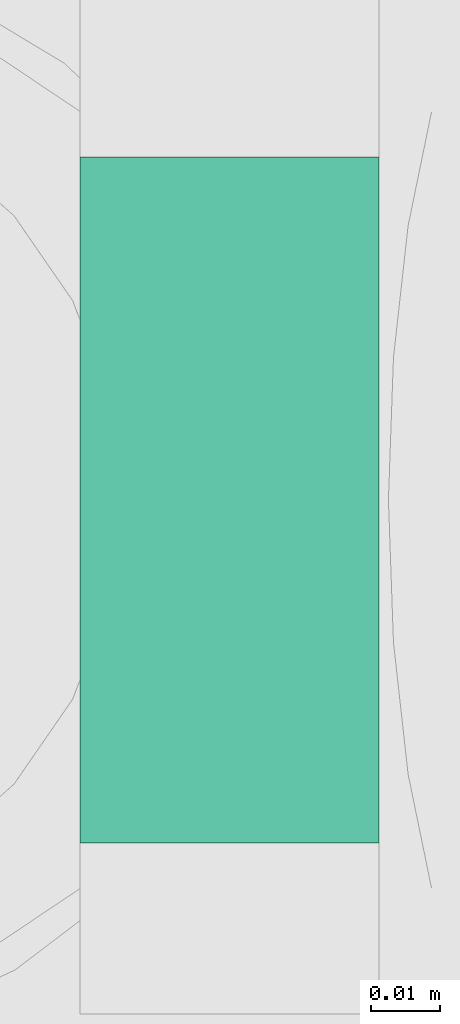
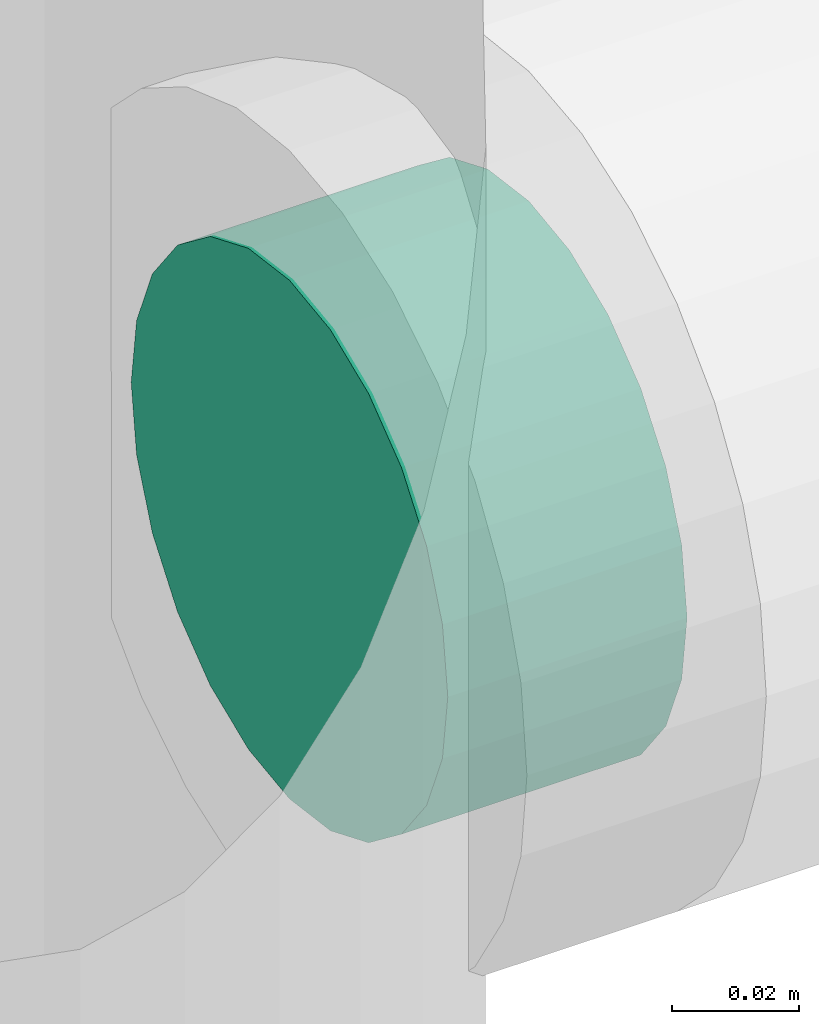
# One storey, part 330 of 337: 1 flow fitting.
"""IFC2X3 building model written with IfcOpenShell, lengths in millimetres."""

from ifc_helpers import new_model, entity, si_unit, converted_unit, derived_unit, direction, frame, origin, place, context, subcontext, project, spatial, faceted_brep, source, transform, mapped, material, type_object, type_shapes, element, save


model = new_model("IFC2X3")

# Units and contexts
model_context = context("Model", 3, precision=0.01, world=origin(), true_north=direction((6.12303176911189e-17, 1.0)))
body_context = subcontext(model_context, "Body", "Model", "MODEL_VIEW")
ifc_project = project(units=[si_unit("LENGTHUNIT", "METRE", prefix="MILLI"), si_unit("AREAUNIT", "SQUARE_METRE"), si_unit("VOLUMEUNIT", "CUBIC_METRE"), converted_unit("PLANEANGLEUNIT", "DEGREE", entity("IfcRatioMeasure", 0.0174532925199433), si_unit("PLANEANGLEUNIT", "RADIAN"), dimensions=[0, 0, 0, 0, 0, 0, 0]), si_unit("MASSUNIT", "GRAM", prefix="KILO"), derived_unit("MASSDENSITYUNIT", [(si_unit("MASSUNIT", "GRAM", prefix="KILO"), 1), (si_unit("LENGTHUNIT", "METRE"), -3)]), derived_unit("MOMENTOFINERTIAUNIT", [(si_unit("LENGTHUNIT", "METRE"), 4)]), si_unit("TIMEUNIT", "SECOND"), si_unit("FREQUENCYUNIT", "HERTZ"), si_unit("THERMODYNAMICTEMPERATUREUNIT", "DEGREE_CELSIUS"), derived_unit("THERMALTRANSMITTANCEUNIT", [(si_unit("MASSUNIT", "GRAM", prefix="KILO"), 1), (si_unit("THERMODYNAMICTEMPERATUREUNIT", "KELVIN"), -1), (si_unit("TIMEUNIT", "SECOND"), -3)]), derived_unit("VOLUMETRICFLOWRATEUNIT", [(si_unit("LENGTHUNIT", "METRE"), 3), (si_unit("TIMEUNIT", "SECOND"), -1)]), derived_unit("MASSFLOWRATEUNIT", [(si_unit("MASSUNIT", "GRAM", prefix="KILO"), 1), (si_unit("TIMEUNIT", "SECOND"), -1)]), derived_unit("ROTATIONALFREQUENCYUNIT", [(si_unit("TIMEUNIT", "SECOND"), -1)]), si_unit("ELECTRICCURRENTUNIT", "AMPERE"), si_unit("ELECTRICVOLTAGEUNIT", "VOLT"), si_unit("POWERUNIT", "WATT"), si_unit("FORCEUNIT", "NEWTON", prefix="KILO"), si_unit("ILLUMINANCEUNIT", "LUX"), si_unit("LUMINOUSFLUXUNIT", "LUMEN"), si_unit("LUMINOUSINTENSITYUNIT", "CANDELA"), derived_unit("USERDEFINED", [(si_unit("MASSUNIT", "GRAM", prefix="KILO"), -1), (si_unit("LENGTHUNIT", "METRE"), -2), (si_unit("TIMEUNIT", "SECOND"), 3), (si_unit("LUMINOUSFLUXUNIT", "LUMEN"), 1)]), derived_unit("LINEARVELOCITYUNIT", [(si_unit("LENGTHUNIT", "METRE"), 1), (si_unit("TIMEUNIT", "SECOND"), -1)]), si_unit("PRESSUREUNIT", "PASCAL"), derived_unit("USERDEFINED", [(si_unit("LENGTHUNIT", "METRE"), -2), (si_unit("MASSUNIT", "GRAM", prefix="KILO"), 1), (si_unit("TIMEUNIT", "SECOND"), -2)]), derived_unit("LINEARFORCEUNIT", [(si_unit("MASSUNIT", "GRAM", prefix="KILO"), 1), (si_unit("LENGTHUNIT", "METRE"), 1), (si_unit("TIMEUNIT", "SECOND"), -2), (si_unit("LENGTHUNIT", "METRE"), -1)]), derived_unit("PLANARFORCEUNIT", [(si_unit("MASSUNIT", "GRAM", prefix="KILO"), 1), (si_unit("LENGTHUNIT", "METRE"), 1), (si_unit("TIMEUNIT", "SECOND"), -2), (si_unit("LENGTHUNIT", "METRE"), -2)])], contexts=[model_context])

# Site, building, storey
site_placement = place(None, origin())
site = spatial("IfcSite", under=ifc_project, at=site_placement, CompositionType="ELEMENT")
building_placement = place(site_placement, origin())
building = spatial("IfcBuilding", under=site, at=building_placement, CompositionType="ELEMENT")
storey_placement = place(building_placement, origin())
storey = spatial("IfcBuildingStorey", under=building, at=storey_placement, CompositionType="ELEMENT", Elevation=0.0)

# Flow fitting
ifc_material = material()
duct_fitting_type = type_object("IfcDuctFittingType", PredefinedType="NOTDEFINED", material=ifc_material)
shared_shape = source(origin(), body_context, "Body", "Brep", [
    faceted_brep([(20.03, 12.94, -48.3), (20.03, 25.0, -43.3), (20.03, 35.36, -35.36), (20.03, 43.3, -25.0), (20.03, 48.3, -12.94), (20.03, 50.0, 0.0), (20.03, 48.3, 12.94), (20.03, 43.3, 25.0), (20.03, 35.36, 35.36), (20.03, 25.0, 43.3), (20.03, 12.94, 48.3), (20.03, 0.0, 50.0), (20.03, -12.94, 48.3), (20.03, -25.0, 43.3), (20.03, -35.36, 35.36), (20.03, -43.3, 25.0), (20.03, -48.3, 12.94), (20.03, -50.0, 0.0), (20.03, -48.3, -12.94), (20.03, -43.3, -25.0), (20.03, -35.36, -35.36), (20.03, -25.0, -43.3), (20.03, -12.94, -48.3), (20.03, 0.0, -50.0), (0.0, 0.0, 50.0), (0.0, 12.94, 48.3), (-23.62, 12.94, 48.3), (-23.62, 0.0, 50.0), (0.0, 25.0, 43.3), (-23.62, 25.0, 43.3), (0.0, 35.36, 35.36), (-23.62, 35.36, 35.36), (0.0, 43.3, 25.0), (0.0, 48.3, 12.94), (-23.62, 48.3, 12.94), (-23.62, 43.3, 25.0), (0.0, 50.0, 0.0), (-23.62, 50.0, 0.0), (0.0, 48.3, -12.94), (-23.62, 48.3, -12.94), (0.0, 43.3, -25.0), (-23.62, 43.3, -25.0), (0.0, 35.36, -35.36), (-23.62, 35.36, -35.36), (0.0, 25.0, -43.3), (0.0, 12.94, -48.3), (-23.62, 12.94, -48.3), (-23.62, 25.0, -43.3), (0.0, 0.0, -50.0), (-23.62, 0.0, -50.0), (0.0, -12.94, -48.3), (-23.62, -12.94, -48.3), (0.0, -25.0, -43.3), (-23.62, -25.0, -43.3), (0.0, -35.36, -35.36), (-23.62, -35.36, -35.36), (0.0, -43.3, -25.0), (0.0, -48.3, -12.94), (-23.62, -48.3, -12.94), (-23.62, -43.3, -25.0), (0.0, -50.0, 0.0), (-23.62, -50.0, 0.0), (0.0, -48.3, 12.94), (-23.62, -48.3, 12.94), (0.0, -43.3, 25.0), (-23.62, -43.3, 25.0), (0.0, -35.36, 35.36), (-23.62, -35.36, 35.36), (0.0, -25.0, 43.3), (0.0, -12.94, 48.3), (-23.62, -12.94, 48.3), (-23.62, -25.0, 43.3)], [[[0, 1, 2, 3, 4, 5, 6, 7, 8, 9, 10, 11, 12, 13, 14, 15, 16, 17, 18, 19, 20, 21, 22, 23]], [[24, 11, 10, 25, 26, 27]], [[25, 10, 9, 28, 29, 26]], [[28, 9, 8, 30, 31, 29]], [[32, 7, 6, 33, 34, 35]], [[33, 6, 5, 36, 37, 34]], [[30, 8, 7, 32, 35, 31]], [[36, 5, 4, 38, 39, 37]], [[38, 4, 3, 40, 41, 39]], [[40, 3, 2, 42, 43, 41]], [[44, 1, 0, 45, 46, 47]], [[45, 0, 23, 48, 49, 46]], [[42, 2, 1, 44, 47, 43]], [[48, 23, 22, 50, 51, 49]], [[50, 22, 21, 52, 53, 51]], [[52, 21, 20, 54, 55, 53]], [[56, 19, 18, 57, 58, 59]], [[57, 18, 17, 60, 61, 58]], [[54, 20, 19, 56, 59, 55]], [[60, 17, 16, 62, 63, 61]], [[62, 16, 15, 64, 65, 63]], [[64, 15, 14, 66, 67, 65]], [[68, 13, 12, 69, 70, 71]], [[69, 12, 11, 24, 27, 70]], [[66, 14, 13, 68, 71, 67]], [[49, 51, 53, 55, 59, 58, 61, 63, 65, 67, 71, 70, 27, 26, 29, 31, 35, 34, 37, 39, 41, 43, 47, 46]]]),
])
type_shapes(duct_fitting_type, [shared_shape])
flow_fitting_placement = place(storey_placement, frame((59629.99, 11524.89, 3450.0), z_axis=(0.0, -1.0, 0.0), x_axis=(1.0, 0.0, 0.0)))
element("IfcFlowFitting", 1, at=flow_fitting_placement, inside=storey, type_object=duct_fitting_type, material=ifc_material, context=body_context, shape_type="MappedRepresentation", body=[
    mapped(shared_shape, transform((0.0, 0.0, 0.0), scale=1.0)),
])

save(model, "model.ifc")
